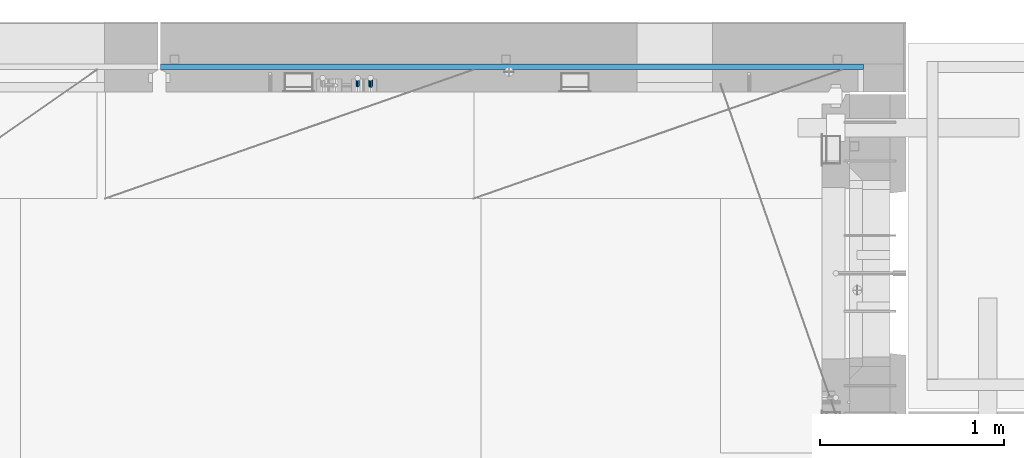
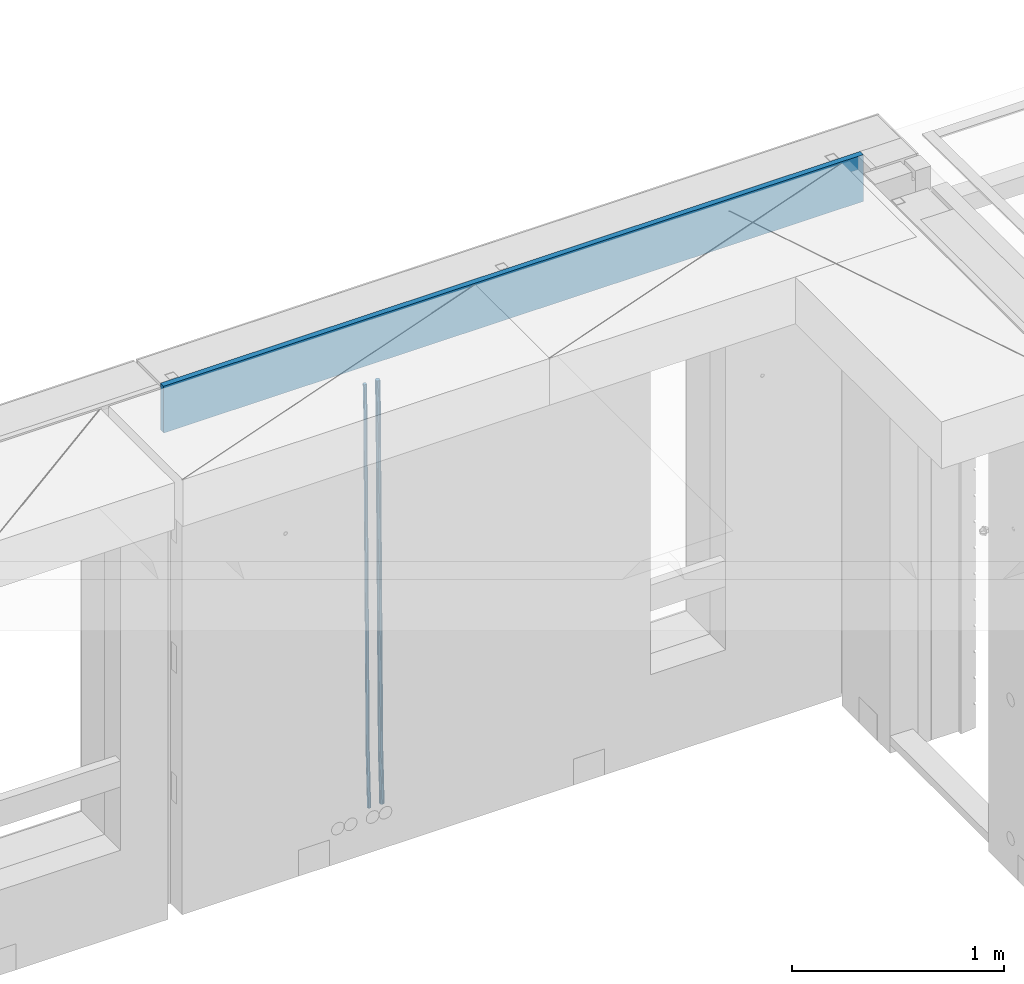
# One storey, part 128 of 350: 3 beams, 1 element without a shape of its own.
"""IFC2X3 building model written with IfcOpenShell, lengths in millimetres."""

from ifc_helpers import new_model, si_unit, frame, origin_with_axes, place, context, subcontext, project, spatial, faceted_brep, material, type_object, element, aggregate, save


model = new_model("IFC2X3")

# Units and contexts
model_context = context("Model", 3, precision=1e-05, world=origin_with_axes())
body_context = subcontext(model_context, "Body", "Model", "MODEL_VIEW")
ifc_project = project(units=[si_unit("LENGTHUNIT", "METRE", prefix="MILLI"), si_unit("AREAUNIT", "SQUARE_METRE"), si_unit("VOLUMEUNIT", "CUBIC_METRE"), si_unit("MASSUNIT", "GRAM", prefix="KILO"), si_unit("TIMEUNIT", "SECOND"), si_unit("PLANEANGLEUNIT", "RADIAN"), si_unit("SOLIDANGLEUNIT", "STERADIAN"), si_unit("THERMODYNAMICTEMPERATUREUNIT", "DEGREE_CELSIUS"), si_unit("LUMINOUSINTENSITYUNIT", "LUMEN")], contexts=[model_context])

# Site, building, storey
site_placement = place(None, origin_with_axes())
site = spatial("IfcSite", under=ifc_project, at=site_placement, CompositionType="ELEMENT")
building_placement = place(site_placement, origin_with_axes())
building = spatial("IfcBuilding", under=site, at=building_placement, CompositionType="ELEMENT")
storey_placement = place(building_placement, origin_with_axes())
storey = spatial("IfcBuildingStorey", under=building, at=storey_placement, Name="2", CompositionType="ELEMENT", Elevation=0.0)

# Assembly, beams
assembly_placement = place(storey_placement, origin_with_axes())
assembly = element("IfcElementAssembly", 1, at=assembly_placement, inside=storey, AssemblyPlace="NOTDEFINED", PredefinedType="REINFORCEMENT_UNIT")
ifc_material_1 = material()
beam_type_1 = type_object("IfcBeamType", Name="D20", PredefinedType="NOTDEFINED")
beam_1_placement = place(assembly_placement, frame((28790.0000000039, 22654.9999977209, 84990.0), z_axis=(-0.000205762999925498, 0.999642804629538, -0.0267249099901004), x_axis=(4.30000201928125e-08, 0.0267249099948059, 0.999642825806181)))
beam_1 = element("IfcBeam", 2, at=beam_1_placement, type_object=beam_type_1, material=ifc_material_1, Name="JM20", ObjectType="D20", context=body_context, shape_type="Brep", body=[
    faceted_brep([(0.0, -10.0, 0.0), (-4.19531716033816e-08, -7.07106781186667, -7.07106781187031), (60.4266690400545, -7.0710677960451, -7.07106780570757), (60.4266690441291, -9.99999998418934, 6.15546014159918e-09), (0.0, 0.0, -10.0), (60.426669036824, 1.58106558956206e-08, -9.99999999384454), (4.196772351861e-08, 7.07106781186303, -7.07106781186667), (60.4266690363438, 7.07106782768096, -7.07106780570757), (0.0, 10.0, 0.0), (60.4266690388904, 10.0000000158179, 6.15182216279209e-09), (4.196772351861e-08, 7.07106781185939, 7.07106781185939), (60.4266690429649, 7.07106782768096, 7.07106781802577), (0.0, 0.0, 10.0), (60.4266690461809, 1.58179318532348e-08, 10.0000000061555), (-4.19531716033816e-08, -7.07106781187031, 7.07106781185939), (60.4266690466611, -7.07106779605238, 7.07106781802213), (61.0378400410118, -7.07106779588503, -7.07106780564936), (60.991799419251, -9.99999998403655, 6.21366780251265e-09), (61.0569027789461, 1.5985278878361e-08, -9.99999999378269), (61.0378209396877, 7.07106782784831, -7.07106780564936), (60.9917724058905, 10.0000000159635, 6.21366780251265e-09), (60.9457317841297, 7.07106782781193, 7.0710678180767), (60.9266690461809, 1.59488990902901e-08, 10.0000000062028), (60.9457508854539, -7.07106779591413, 7.0710678180767), (61.6489592143771, -7.07106614513759, -7.06310863441468), (61.5568818710308, -9.9999984576425, 0.00735959856683621), (61.6870830769039, 1.71821739058942e-06, -9.99179257185824), (61.6489210170112, 7.07106947854481, -7.06310888312146), (61.556827851804, 10.0000015422847, 0.00735924683976918), (61.4647505084577, 7.07106922979438, 7.07782747982128), (61.4266266459163, 1.36643211590126e-06, 10.0065114172685), (61.464788705809, -7.07106639389531, 7.07782772852806), (176.543135720174, -7.07075579406956, -5.56673531796696), (176.451058376813, -9.99968810657447, 1.50373291501455), (176.581259582701, 0.000312069292704109, -8.49541925541052), (176.543097522794, 7.07137982961285, -5.56673556667374), (176.451004357587, 10.00031189336, 1.50373256329476), (176.35892701424, 7.07137958085514, 8.57420079627263), (176.320803151699, 0.000311717507429421, 11.5028847337162), (176.358965211621, -7.07075604281999, 8.57420104497578), (177.098753836006, -7.07075429323595, -5.55949898843028), (176.98362511232, -9.99968666800123, 1.510669025065), (177.146421932586, 0.000313595905026887, -8.48805862247536), (177.098706077581, 7.07138133041735, -5.55949936166144), (176.983557571715, 10.0003133318824, 1.51066849724157), (176.868428848029, 7.07138095712435, 8.58083651073321), (176.820760751449, 0.000313067976094317, 11.5093961447819), (176.868476606425, -7.07075466652896, 8.58083688396073), (177.654312950661, -7.07075204110879, -5.54863964998367), (177.516135294456, -9.99968450931192, 1.52107783331303), (177.711524267797, 0.000315886711177882, -8.47701274570863), (177.654255632195, 7.07138358250813, -5.54864021007961), (177.516054233929, 10.0003154905207, 1.5210770412159), (177.377876577739, 7.0713830223176, 8.59079452451624), (177.320665260588, 0.000315094497636892, 11.5191676202448), (177.377933896176, -7.07075260129932, 8.59079508461218), (299.436796249574, -7.07025836271714, -3.1681962331204), (299.298618593355, -9.99919083092027, 3.90152125031091), (299.494007566798, 0.000809565110102994, -6.09656932889993), (299.436738931283, 7.07187726089978, -3.16819679320906), (299.298537533061, 10.0008091689197, 3.90152045822106), (299.160359876842, 7.07187670072017, 10.9712379416487), (299.103148559603, 0.000808772889286047, 13.8996110374392), (299.160417195119, -7.07025892290039, 10.9712385017483), (299.98743051647, -7.07025613056248, -3.15743315966392), (299.971788958996, -9.99918809853989, 3.91467979818117), (299.993912075952, 0.000811591617093654, -6.08679785393178), (299.987423933868, 7.07187949325817, -3.1574327280432), (299.971753863239, 10.0008119014747, 3.91467990454839), (299.95611230444, 7.07187992653053, 10.9867922621015), (299.949630744944, 0.000812204350950196, 13.9161569563694), (299.956118887014, -7.07025569729012, 10.9867918304735), (300.538107039494, -7.07025785017686, -3.16575821840888), (300.644985195438, -9.99919020432935, 3.90450175465594), (300.493854948218, 0.000810030429420294, -6.09435592770024), (300.538151196495, 7.071877773491, -3.16575855385963), (300.645047642858, 10.0008097955724, 3.90450128024895), (300.751925798773, 7.07187744142357, 10.9747612533101), (300.796177890064, 0.000809560813650023, 13.9033589625978), (300.751881641787, -7.07025818224065, 10.9747615887682), (2293.36490490142, -7.07648090940347, -33.2930642912361), (2293.47178305736, -10.0054132635523, -26.2228043181785), (2293.32065281013, -0.00541302880083094, -36.2216620005347), (2293.36494905842, 7.06565471425711, -33.2930646266868), (2293.47184550477, 9.99458673634581, -26.2228047925819), (2293.57872366071, 7.06565438219332, -19.1525448195243), (2293.62297575199, -0.00541349841296324, -16.2239471102366), (2293.57867950371, -7.0764812414709, -19.1525444840736), (2294.0658245362, -7.07648309818615, -33.3036607065333), (2294.05312277409, -10.0054150789219, -26.2315929392535), (2294.10928714235, -0.00541549149056664, -36.2335844756526), (2294.15805078732, 7.06565223761572, -33.3050546393533), (2294.18355038921, 9.99458451388637, -26.2335642579346), (2294.17084862708, 7.06565253314329, -19.1614964906439), (2294.12738602093, -0.00541507354500936, -16.2315727215355), (2294.07862237596, -7.07648280265857, -19.1601025578348), (2294.76670261032, -7.08562269121467, -33.294332712383), (2294.63442802057, -10.0129954178956, -26.2238563411993), (2294.89787471293, -0.0156988342423574, -36.2230891548279), (2294.95110548967, 7.05531064255774, -33.2944998654275), (2294.89521307347, 9.98530428734011, -26.2240927312887), (2294.76293848372, 7.0579315606592, -19.1536163601049), (2294.63176638114, -0.0119922963167483, -16.2248599176673), (2294.57853560438, -7.08300177311321, -19.1534492070678), (2316.52657204497, -7.36937582653991, -33.0047303660212), (2316.39429745522, -10.2967485532172, -25.9342539948302), (2316.65774414754, -0.299451969567599, -35.9334868084661), (2316.7109749243, 6.7715575072325, -33.0048975190657), (2316.65508250811, 9.70155115201487, -25.9344903849269), (2316.52280791836, 6.7741784253376, -18.8640140137468), (2316.39163581574, -0.295745431634714, -15.9352575713092), (2316.33840503903, -7.36675490843481, -18.863846860706), (2317.16202064224, -7.37766220584308, -32.9962731735213), (2317.05438744847, -10.3053562613532, -25.9254688497131), (2317.23607125619, -0.306993473008333, -35.925789846493), (2317.23316144495, 6.76474808850253, -32.9979477328052), (2317.15499573652, 9.6950321815566, -25.9278370341635), (2317.04736254275, 6.7673381260538, -18.8570327103698), (2316.97331192881, -0.303330606784584, -15.9275160373909), (2316.97622174003, -7.37507216829545, -18.8553581510787), (2317.79752306276, -7.37578610372293, -32.9880110666527), (2317.71453320107, -10.3033876998124, -25.9168792378296), (2317.81444760226, -0.305295583297266, -35.918287695793), (2317.75539265381, 6.76628640723357, -32.9911928173897), (2317.65495180529, 9.69652304524061, -25.9213789128698), (2317.5719619436, 6.76892144914746, -18.8502470840467), (2317.55503740412, -0.301569071270933, -15.9199704549137), (2317.61409235255, -7.3731510618054, -18.847065333317), (2417.8183084176, -7.07752398473531, -31.6906369377139), (2417.73531855589, -10.0051255808248, -24.6195051088798), (2417.83523295709, -0.007033464313281, -34.6209135668432), (2417.77617800863, 7.06454852621755, -31.6938186884508), (2417.67573716014, 9.99478516423187, -24.6240047839383), (2417.59274729842, 7.06718356813872, -17.5528729551006), (2417.57582275895, -0.00330695228694822, -14.6225963259749), (2417.6348777074, -7.07488894281778, -17.5496912043673)], [[[0, 1, 2, 3]], [[1, 4, 5, 2]], [[4, 6, 7, 5]], [[6, 8, 9, 7]], [[8, 10, 11, 9]], [[10, 12, 13, 11]], [[12, 14, 15, 13]], [[14, 0, 3, 15]], [[14, 12, 10, 8, 6, 4, 1, 0]], [[3, 2, 16, 17]], [[2, 5, 18, 16]], [[5, 7, 19, 18]], [[7, 9, 20, 19]], [[9, 11, 21, 20]], [[11, 13, 22, 21]], [[13, 15, 23, 22]], [[15, 3, 17, 23]], [[17, 16, 24, 25]], [[16, 18, 26, 24]], [[18, 19, 27, 26]], [[19, 20, 28, 27]], [[20, 21, 29, 28]], [[21, 22, 30, 29]], [[22, 23, 31, 30]], [[23, 17, 25, 31]], [[25, 24, 32, 33]], [[24, 26, 34, 32]], [[26, 27, 35, 34]], [[27, 28, 36, 35]], [[28, 29, 37, 36]], [[29, 30, 38, 37]], [[30, 31, 39, 38]], [[31, 25, 33, 39]], [[33, 32, 40, 41]], [[32, 34, 42, 40]], [[34, 35, 43, 42]], [[35, 36, 44, 43]], [[36, 37, 45, 44]], [[37, 38, 46, 45]], [[38, 39, 47, 46]], [[39, 33, 41, 47]], [[41, 40, 48, 49]], [[40, 42, 50, 48]], [[42, 43, 51, 50]], [[43, 44, 52, 51]], [[44, 45, 53, 52]], [[45, 46, 54, 53]], [[46, 47, 55, 54]], [[47, 41, 49, 55]], [[49, 48, 56, 57]], [[48, 50, 58, 56]], [[50, 51, 59, 58]], [[51, 52, 60, 59]], [[52, 53, 61, 60]], [[53, 54, 62, 61]], [[54, 55, 63, 62]], [[55, 49, 57, 63]], [[57, 56, 64, 65]], [[56, 58, 66, 64]], [[58, 59, 67, 66]], [[59, 60, 68, 67]], [[60, 61, 69, 68]], [[61, 62, 70, 69]], [[62, 63, 71, 70]], [[63, 57, 65, 71]], [[65, 64, 72, 73]], [[64, 66, 74, 72]], [[66, 67, 75, 74]], [[67, 68, 76, 75]], [[68, 69, 77, 76]], [[69, 70, 78, 77]], [[70, 71, 79, 78]], [[71, 65, 73, 79]], [[73, 72, 80, 81]], [[72, 74, 82, 80]], [[74, 75, 83, 82]], [[75, 76, 84, 83]], [[76, 77, 85, 84]], [[77, 78, 86, 85]], [[78, 79, 87, 86]], [[79, 73, 81, 87]], [[81, 80, 88, 89]], [[80, 82, 90, 88]], [[82, 83, 91, 90]], [[83, 84, 92, 91]], [[84, 85, 93, 92]], [[85, 86, 94, 93]], [[86, 87, 95, 94]], [[87, 81, 89, 95]], [[89, 88, 96, 97]], [[88, 90, 98, 96]], [[90, 91, 99, 98]], [[91, 92, 100, 99]], [[92, 93, 101, 100]], [[93, 94, 102, 101]], [[94, 95, 103, 102]], [[95, 89, 97, 103]], [[97, 96, 104, 105]], [[96, 98, 106, 104]], [[98, 99, 107, 106]], [[99, 100, 108, 107]], [[100, 101, 109, 108]], [[101, 102, 110, 109]], [[102, 103, 111, 110]], [[103, 97, 105, 111]], [[105, 104, 112, 113]], [[104, 106, 114, 112]], [[106, 107, 115, 114]], [[107, 108, 116, 115]], [[108, 109, 117, 116]], [[109, 110, 118, 117]], [[110, 111, 119, 118]], [[111, 105, 113, 119]], [[113, 112, 120, 121]], [[112, 114, 122, 120]], [[114, 115, 123, 122]], [[115, 116, 124, 123]], [[116, 117, 125, 124]], [[117, 118, 126, 125]], [[118, 119, 127, 126]], [[119, 113, 121, 127]], [[121, 120, 128, 129]], [[120, 122, 130, 128]], [[122, 123, 131, 130]], [[123, 124, 132, 131]], [[124, 125, 133, 132]], [[125, 126, 134, 133]], [[126, 127, 135, 134]], [[127, 121, 129, 135]], [[130, 131, 132, 133, 134, 135, 129, 128]]]),
])
beam_type_2 = type_object("IfcBeamType", Name="D25", PredefinedType="NOTDEFINED")
beam_2_placement = place(assembly_placement, frame((28860.0000000039, 22654.9999977209, 84990.0), z_axis=(-0.000205762999925498, 0.999642804629538, -0.0267249099901004), x_axis=(4.30000201928125e-08, 0.0267249099948059, 0.999642825806181)))
beam_2 = element("IfcBeam", 3, at=beam_2_placement, type_object=beam_type_2, material=ifc_material_1, Name="JM25", ObjectType="D25", context=body_context, shape_type="Brep", body=[
    faceted_brep([(-7.41420080885291e-08, -12.5, -3.63797880709171e-12), (-6.42030499875546e-08, -10.8253175473074, -6.25000000000364), (60.4103898235917, -10.8253175318459, -6.2499999938409), (60.4103898269532, -12.4999999845422, 6.16273609921336e-09), (-3.70782800018787e-08, -6.25000000000364, -10.8253175473074), (60.4103898202884, -6.24999998454587, -10.8253175411446), (-1.45519152283669e-11, -3.63797880709171e-12, -12.5), (60.4103898179019, 1.54577719513327e-08, -12.4999999938373), (3.70637280866504e-08, 6.25, -10.8253175473074), (60.410389817087, 6.25000001545777, -10.825317541141), (6.42030499875546e-08, 10.8253175473001, -6.25000000000364), (60.410389818062, 10.8253175627578, -6.24999999383726), (7.41420080885291e-08, 12.4999999999927, 0.0), (60.4103898205503, 12.5000000154541, 6.16273609921336e-09), (6.42176019027829e-08, 10.8253175473001, 6.24999999999636), (60.4103898238973, 10.8253175627651, 6.2500000061591), (3.70928319171071e-08, 6.24999999999636, 10.8253175473037), (60.4103898272151, 6.25000001546141, 10.8253175534664), (1.45519152283669e-11, -3.63797880709171e-12, 12.4999999999964), (60.4103898296162, 1.54541339725256e-08, 12.5000000061591), (-3.7049176171422e-08, -6.25000000000364, 10.8253175473001), (60.4103898304165, -6.24999998454587, 10.8253175534701), (-6.41884980723262e-08, -10.8253175473074, 6.25), (60.4103898294561, -10.8253175318459, 6.25000000616637), (61.0324985728803, -10.8253175316895, -6.24999999377542), (60.991802792938, -12.4999999843931, 6.22458173893392e-09), (61.0622854283865, -6.24999998437852, -10.8253175410755), (61.0731819955545, 1.5628756955266e-08, -12.4999999937718), (61.0622685480339, 6.25000001562512, -10.8253175410791), (61.032469335245, 10.8253175629216, -6.24999999377178), (60.9917690322181, 12.5000000156033, 6.22458173893392e-09), (60.9510732522613, 10.8253175629034, 6.25000000621731), (60.9212863967696, 6.25000001558874, 10.8253175535247), (60.9103898296162, 1.55814632307738e-08, 12.5000000062137), (60.9213032771368, -6.24999998441126, 10.8253175535174), (60.9511024898966, -10.8253175317113, 6.25000000621731), (61.6545545670233, -10.8253158516927, -6.24189838219536), (61.573166454793, -12.499998414296, 0.00757164385504439), (61.7141257553885, -6.24999822394238, -10.8168280205282), (61.7359179680789, 1.80548886419274e-06, -12.491368569139), (61.7140919992817, 6.25000177601396, -10.8168282403167), (61.6544960997562, 10.8253192428383, -6.2418987628771), (61.5730989426083, 12.5000015856094, 0.0075712042817031), (61.4917108303925, 10.8253190230062, 6.25704123032847), (61.4321396420273, 6.25000139525582, 10.8319708686649), (61.4103474293224, 1.36582457344048e-06, 12.5065114172721), (61.4321733981196, -6.24999860470052, 10.8319710884571), (61.4917692976451, -10.8253160715249, 6.25704161101385), (176.524302641745, -10.8250056210964, -4.74584321979273), (176.442914529529, -12.4996881836996, 1.50362680625403), (176.583873830095, -6.24968799334965, -9.3207728581292), (176.605666042786, 0.000312036081595579, -10.9953134067364), (176.583840074018, 6.25031200660669, -9.32077307791769), (176.524244174492, 10.8256294734347, -4.74584360047811), (176.44284701733, 12.5003118162058, 1.50362636668069), (176.361458905099, 10.8256292535989, 7.75309639272746), (176.301887716749, 6.25031162585219, 12.3280260310676), (176.280095504058, 0.000311596420942806, 14.0025665796711), (176.301921472827, -6.24968837410415, 12.3280262508561), (176.361517372367, -10.8250058409321, 7.75309677341284), (177.085397012124, -10.8250041057399, -4.73853556792164), (176.983633547483, -12.4996867233749, 1.51066909103247), (177.159881729676, -6.24968643771717, -9.31327097355097), (177.187129580227, 0.000313606451527448, -10.987740468332), (177.159839524218, 6.25031356221734, -9.31327130338468), (177.085323910098, 10.8256309887511, -4.73853613920801), (176.983549136537, 12.5003132764905, 1.51066843136869), (176.881785671867, 10.8256306588555, 7.7598730903228), (176.80730095433, 6.25031299082912, 12.3346084959521), (176.780053103794, 0.000312946667690994, 14.0090779907332), (176.807343159802, -6.2496870091054, 12.3346088257895), (176.881858773908, -10.8250044356355, 7.7598736616128), (177.646431799818, -10.8250018318176, -4.72756919822132), (177.524295146417, -12.4996845320202, 1.52123723245313), (177.735828462886, -6.24968410334986, -9.30201312475765), (177.768531371941, 0.00031596292683389, -10.9763759912421), (177.735777808921, 6.25031589654827, -9.30201361973741), (177.646344064575, 10.8256332626152, -4.72757005553649), (177.524193838486, 12.5003154677688, 1.52123624250817), (177.402057185071, 10.8256327675663, 7.77004267317898), (177.312660521988, 6.2503150390985, 12.3444865997226), (177.279957612933, 0.00031497282179771, 14.0188494661961), (177.312711175953, -6.24968496079964, 12.3444870946951), (177.402144920314, -10.8250023268702, 7.77004353049415), (299.377443161706, -10.8245084454466, -2.34813158632096), (299.255306508276, -12.4991911456491, 3.90067484435349), (299.466839824803, -6.24919071697514, -6.92257551286093), (299.499542733873, 0.0008093492979242, -8.59693837933446), (299.466789170867, 6.250809282923, -6.92257600783341), (299.377355426492, 10.8261266489935, -2.34813244364341), (299.255205200388, 12.5008088541435, 3.90067385440125), (299.133068546944, 10.826126153941, 10.1494802850757), (299.043671883861, 6.25080842546959, 14.7239242116229), (299.010968974762, 0.000808359200163977, 16.3982870780892), (299.043722537797, -6.24919157442127, 14.7239247065918), (299.133156282158, -10.8245089404954, 10.1494811423981), (299.98561436501, -10.8245059804758, -2.33624385599614), (299.97179243555, -12.4991882411778, 3.91467976726199), (299.995742293278, -6.24918857328521, -6.91223722345239), (299.999447243041, 0.000811375455668895, -8.58716690387519), (299.995736475976, 6.25081142679483, -6.91223684201032), (299.985604289133, 10.8261291142808, -2.33624319533556), (299.971750386685, 12.5008117588586, 3.91467993563856), (299.957928457196, 10.8261294971744, 10.1656035610831), (299.947800528913, 6.25081208998381, 14.7415969285394), (299.944095579151, 0.00081214124293183, 16.4165266089549), (299.947806346216, -6.24918791008895, 14.7415965471009), (299.957938533058, -10.8245055975785, 10.1656029004225), (300.593832239858, -10.8245078794353, -2.34543881707941), (300.688302931099, -12.4991904788549, 3.90384712594823), (300.524685350189, -6.24919022474205, -6.92023371784308), (300.499390115292, 0.000809814544481924, -8.59472497713432), (300.524724372954, 6.25080977519247, -6.92023401429469), (300.593899829313, 10.8261272150703, -2.34543933054374), (300.688380976673, 12.5008095210287, 3.90384653304136), (300.782851667915, 10.8261269216127, 10.1531324760799), (300.851998557599, 6.25080926691589, 14.7279273768363), (300.877293792495, 0.000809227632998955, 16.4024186361276), (300.851959534804, -6.24919073302226, 14.7279276732806), (300.782784078474, -10.8245081728965, 10.153132989537), (2293.32930409742, -10.8307295605009, -32.4713622331001), (2293.42377478865, -12.5054121599169, -26.2220762900724), (2293.26015720774, -6.2554119058077, -37.0461571338565), (2293.23486197284, -0.00541186651753378, -38.7206483931477), (2293.26019623051, 6.24458809413409, -37.0461574303008), (2293.32937168686, 10.8199055340046, -32.4713627465644), (2293.42385283421, 12.4945878399631, -26.2220768829684), (2293.51832352545, 10.8199052405434, -19.972790939948), (2293.58747041514, 6.24458758585388, -15.3979960391844), (2293.61276565003, -0.00541245343265473, -13.7235047798931), (2293.58743139236, -6.25541241408428, -15.3979957427327), (2293.51825593603, -10.8307298539585, -19.9727904264691), (2294.0420846676, -10.8307317859326, -32.4821379598216), (2294.03681932652, -12.5054140739521, -26.2313442200393), (2294.06778164886, -6.2554144273563, -37.0583666982457), (2294.10702478497, -0.00541458957013674, -38.7338336404937), (2294.14929890928, 6.24458531819619, -37.0595987724118), (2294.18327670435, 10.8199028679592, -32.4842719748667), (2294.1998538474, 12.4945854171456, -26.2338083683717), (2294.19458850632, 10.819903129126, -19.9830146285858), (2294.16889152506, 6.24458577054975, -15.4067858901581), (2294.12964838895, -0.0054140672327776, -13.7313189479173), (2294.08737426462, -6.2554139749991, -15.4055538159919), (2294.05339646956, -10.8307315247621, -19.9808806135297), (2294.75482297382, -10.84002603931, -32.4726521173216), (2294.64982751427, -12.513407826169, -26.2231856868602), (2294.87535820232, -6.26594539088183, -37.0476186524102), (2294.97913588268, -0.0167870967634371, -38.7222267036377), (2295.0383488692, 6.23299192477134, -37.0477663960555), (2295.03713108998, 10.8087684320271, -32.4729080168181), (2294.97580884799, 12.4844668051373, -26.2234811741473), (2294.87081338844, 10.8110850182784, -19.9740147436787), (2294.7502781599, 6.23700436985018, -15.3990482086047), (2294.64650047956, -0.0121539242718427, -13.7244401573698), (2294.58728749304, -6.26193294580662, -15.3989004649666), (2294.58850527227, -10.8377094530588, -19.9737588441894), (2316.44667268227, -11.1228921988077, -32.1839550346631), (2316.34167722271, -12.7962739856739, -25.9344886042054), (2316.56720791078, -6.54881155039038, -36.7589215697517), (2316.67098559113, -0.299653256264719, -38.4335296209792), (2316.73019857766, 5.95012576527006, -36.759069313397), (2316.72898079845, 10.5259022725259, -32.1842109341669), (2316.66765855643, 12.2016006456361, -25.9347840914961), (2316.56266309689, 10.5282188587698, -19.6853176610275), (2316.44212786836, 5.95413821035254, -15.1103511259389), (2316.33835018802, -0.295020083769487, -13.4357430747186), (2316.27913720149, -6.54479910530426, -15.1102033823008), (2316.28035498071, -11.1205756125637, -19.685061761531), (2317.13234804722, -11.1318335458927, -32.1748293731798), (2317.04181141085, -12.8054038787741, -25.9251705100723), (2317.2154741603, -6.5572650749491, -36.7502937866229), (2317.26891617525, -0.307450393454928, -38.4255717558117), (2317.27835434731, 5.94297770185585, -36.7517739018112), (2317.24125972588, 10.5192220504723, -32.1773930078925), (2317.16757178486, 12.1950816748285, -25.9281307404563), (2317.0770351485, 10.5215113419545, -19.6784718773561), (2316.99390903539, 5.94694287101083, -15.1030074639057), (2316.94046702047, -0.302871810494253, -13.4277294947169), (2316.9310288484, -6.55329990579412, -15.1015273487101), (2316.96812346982, -11.1295442544142, -19.6759082426288), (2317.81808136747, -11.1298054502913, -32.1659056455355), (2317.74200467508, -12.803315894289, -25.9160547315114), (2317.86379538118, -6.55536082026447, -36.7418676070083), (2317.8668976831, -0.305700748642266, -38.417815303761), (2317.82655701396, 5.94458339541234, -36.7446799039099), (2317.75358262347, 10.5207330230332, -32.1707766866384), (2317.66752794063, 12.1965725370646, -25.9216793252963), (2317.59145124823, 10.5230620930706, -19.6718284112721), (2317.54573723453, 5.94861746304377, -15.0958664497994), (2317.54263493262, -0.301042608574789, -13.4199187530394), (2317.58297560175, -6.55132675263303, -15.0930541529051), (2317.65594999224, -11.1274763802539, -19.6669573701693), (2417.81884292323, -10.831603083323, -30.8687911350135), (2417.74276623082, -12.505113527317, -24.618940220982), (2417.86455693691, -6.25715845329614, -35.4447530964935), (2417.86765923884, -0.00749838167394046, -37.1207007932499), (2417.82731856969, 6.24278576237703, -35.4475653933878), (2417.75434417921, 10.8189353900088, -30.8736621761236), (2417.66828949639, 12.494774904033, -24.6245648147851), (2417.59221280397, 10.8212644600353, -18.3747139007501), (2417.54649879028, 6.2468198300121, -13.79875193927), (2417.54339648837, -0.00284024161010166, -12.1228042425173), (2417.5837371575, -6.25312438566107, -13.795939642383), (2417.65671154798, -10.8292740132893, -18.3698428596399)], [[[0, 1, 2, 3]], [[1, 4, 5, 2]], [[4, 6, 7, 5]], [[6, 8, 9, 7]], [[8, 10, 11, 9]], [[10, 12, 13, 11]], [[12, 14, 15, 13]], [[14, 16, 17, 15]], [[16, 18, 19, 17]], [[18, 20, 21, 19]], [[20, 22, 23, 21]], [[22, 0, 3, 23]], [[22, 20, 18, 16, 14, 12, 10, 8, 6, 4, 1, 0]], [[3, 2, 24, 25]], [[2, 5, 26, 24]], [[5, 7, 27, 26]], [[7, 9, 28, 27]], [[9, 11, 29, 28]], [[11, 13, 30, 29]], [[13, 15, 31, 30]], [[15, 17, 32, 31]], [[17, 19, 33, 32]], [[19, 21, 34, 33]], [[21, 23, 35, 34]], [[23, 3, 25, 35]], [[25, 24, 36, 37]], [[24, 26, 38, 36]], [[26, 27, 39, 38]], [[27, 28, 40, 39]], [[28, 29, 41, 40]], [[29, 30, 42, 41]], [[30, 31, 43, 42]], [[31, 32, 44, 43]], [[32, 33, 45, 44]], [[33, 34, 46, 45]], [[34, 35, 47, 46]], [[35, 25, 37, 47]], [[37, 36, 48, 49]], [[36, 38, 50, 48]], [[38, 39, 51, 50]], [[39, 40, 52, 51]], [[40, 41, 53, 52]], [[41, 42, 54, 53]], [[42, 43, 55, 54]], [[43, 44, 56, 55]], [[44, 45, 57, 56]], [[45, 46, 58, 57]], [[46, 47, 59, 58]], [[47, 37, 49, 59]], [[49, 48, 60, 61]], [[48, 50, 62, 60]], [[50, 51, 63, 62]], [[51, 52, 64, 63]], [[52, 53, 65, 64]], [[53, 54, 66, 65]], [[54, 55, 67, 66]], [[55, 56, 68, 67]], [[56, 57, 69, 68]], [[57, 58, 70, 69]], [[58, 59, 71, 70]], [[59, 49, 61, 71]], [[61, 60, 72, 73]], [[60, 62, 74, 72]], [[62, 63, 75, 74]], [[63, 64, 76, 75]], [[64, 65, 77, 76]], [[65, 66, 78, 77]], [[66, 67, 79, 78]], [[67, 68, 80, 79]], [[68, 69, 81, 80]], [[69, 70, 82, 81]], [[70, 71, 83, 82]], [[71, 61, 73, 83]], [[73, 72, 84, 85]], [[72, 74, 86, 84]], [[74, 75, 87, 86]], [[75, 76, 88, 87]], [[76, 77, 89, 88]], [[77, 78, 90, 89]], [[78, 79, 91, 90]], [[79, 80, 92, 91]], [[80, 81, 93, 92]], [[81, 82, 94, 93]], [[82, 83, 95, 94]], [[83, 73, 85, 95]], [[85, 84, 96, 97]], [[84, 86, 98, 96]], [[86, 87, 99, 98]], [[87, 88, 100, 99]], [[88, 89, 101, 100]], [[89, 90, 102, 101]], [[90, 91, 103, 102]], [[91, 92, 104, 103]], [[92, 93, 105, 104]], [[93, 94, 106, 105]], [[94, 95, 107, 106]], [[95, 85, 97, 107]], [[97, 96, 108, 109]], [[96, 98, 110, 108]], [[98, 99, 111, 110]], [[99, 100, 112, 111]], [[100, 101, 113, 112]], [[101, 102, 114, 113]], [[102, 103, 115, 114]], [[103, 104, 116, 115]], [[104, 105, 117, 116]], [[105, 106, 118, 117]], [[106, 107, 119, 118]], [[107, 97, 109, 119]], [[109, 108, 120, 121]], [[108, 110, 122, 120]], [[110, 111, 123, 122]], [[111, 112, 124, 123]], [[112, 113, 125, 124]], [[113, 114, 126, 125]], [[114, 115, 127, 126]], [[115, 116, 128, 127]], [[116, 117, 129, 128]], [[117, 118, 130, 129]], [[118, 119, 131, 130]], [[119, 109, 121, 131]], [[121, 120, 132, 133]], [[120, 122, 134, 132]], [[122, 123, 135, 134]], [[123, 124, 136, 135]], [[124, 125, 137, 136]], [[125, 126, 138, 137]], [[126, 127, 139, 138]], [[127, 128, 140, 139]], [[128, 129, 141, 140]], [[129, 130, 142, 141]], [[130, 131, 143, 142]], [[131, 121, 133, 143]], [[133, 132, 144, 145]], [[132, 134, 146, 144]], [[134, 135, 147, 146]], [[135, 136, 148, 147]], [[136, 137, 149, 148]], [[137, 138, 150, 149]], [[138, 139, 151, 150]], [[139, 140, 152, 151]], [[140, 141, 153, 152]], [[141, 142, 154, 153]], [[142, 143, 155, 154]], [[143, 133, 145, 155]], [[145, 144, 156, 157]], [[144, 146, 158, 156]], [[146, 147, 159, 158]], [[147, 148, 160, 159]], [[148, 149, 161, 160]], [[149, 150, 162, 161]], [[150, 151, 163, 162]], [[151, 152, 164, 163]], [[152, 153, 165, 164]], [[153, 154, 166, 165]], [[154, 155, 167, 166]], [[155, 145, 157, 167]], [[157, 156, 168, 169]], [[156, 158, 170, 168]], [[158, 159, 171, 170]], [[159, 160, 172, 171]], [[160, 161, 173, 172]], [[161, 162, 174, 173]], [[162, 163, 175, 174]], [[163, 164, 176, 175]], [[164, 165, 177, 176]], [[165, 166, 178, 177]], [[166, 167, 179, 178]], [[167, 157, 169, 179]], [[169, 168, 180, 181]], [[168, 170, 182, 180]], [[170, 171, 183, 182]], [[171, 172, 184, 183]], [[172, 173, 185, 184]], [[173, 174, 186, 185]], [[174, 175, 187, 186]], [[175, 176, 188, 187]], [[176, 177, 189, 188]], [[177, 178, 190, 189]], [[178, 179, 191, 190]], [[179, 169, 181, 191]], [[181, 180, 192, 193]], [[180, 182, 194, 192]], [[182, 183, 195, 194]], [[183, 184, 196, 195]], [[184, 185, 197, 196]], [[185, 186, 198, 197]], [[186, 187, 199, 198]], [[187, 188, 200, 199]], [[188, 189, 201, 200]], [[189, 190, 202, 201]], [[190, 191, 203, 202]], [[191, 181, 193, 203]], [[194, 195, 196, 197, 198, 199, 200, 201, 202, 203, 193, 192]]]),
])
ifc_material_2 = material(Name="CONCRETE/C25/30")
beam_type_3 = type_object("IfcBeamType", Name="270X30", PredefinedType="NOTDEFINED")
beam_3_placement = place(assembly_placement, frame((31535.0, 22755.0, 87605.0), z_axis=(0.0, 0.0, 1.0), x_axis=(-1.0, 3.00000001838171e-08, 0.0)))
beam_3 = element("IfcBeam", 4, at=beam_3_placement, type_object=beam_type_3, material=ifc_material_2, ObjectType="270X30", context=body_context, shape_type="Brep", body=[
    faceted_brep([(0.0, 15.0, -135.0), (0.0, 15.0, 135.0), (3815.00000000003, 15.0, 135.0), (3815.00000000003, 15.0, -135.0), (0.0, -15.0, 135.0), (3815.00000000003, -15.0, 135.0), (0.0, -15.0, -135.0), (3815.00000000003, -15.0, -135.0)], [[[0, 1, 2, 3]], [[1, 4, 5, 2]], [[4, 6, 7, 5]], [[6, 0, 3, 7]], [[5, 7, 3, 2]], [[6, 4, 1, 0]]]),
])
aggregate(assembly, [beam_1, beam_2, beam_3])

save(model, "model.ifc")
